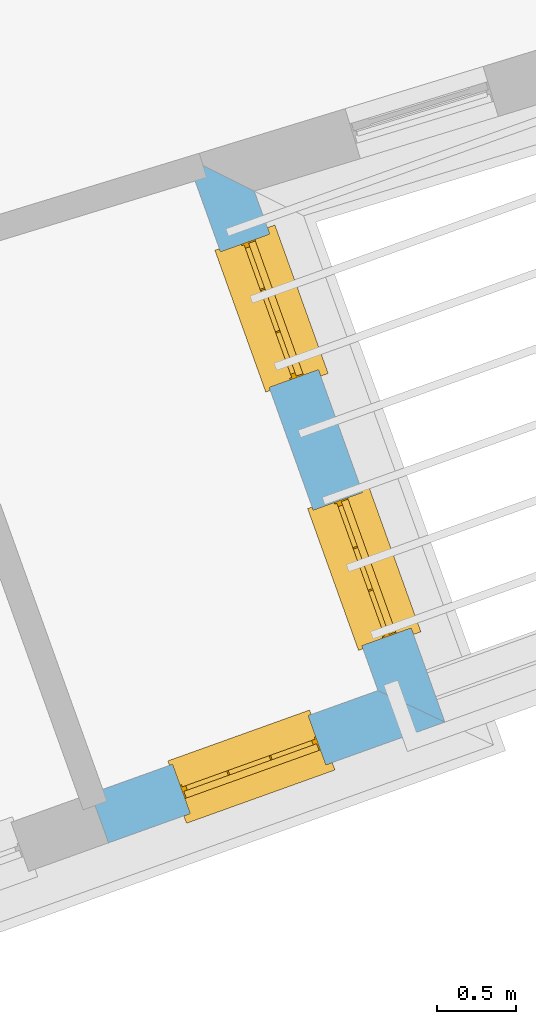
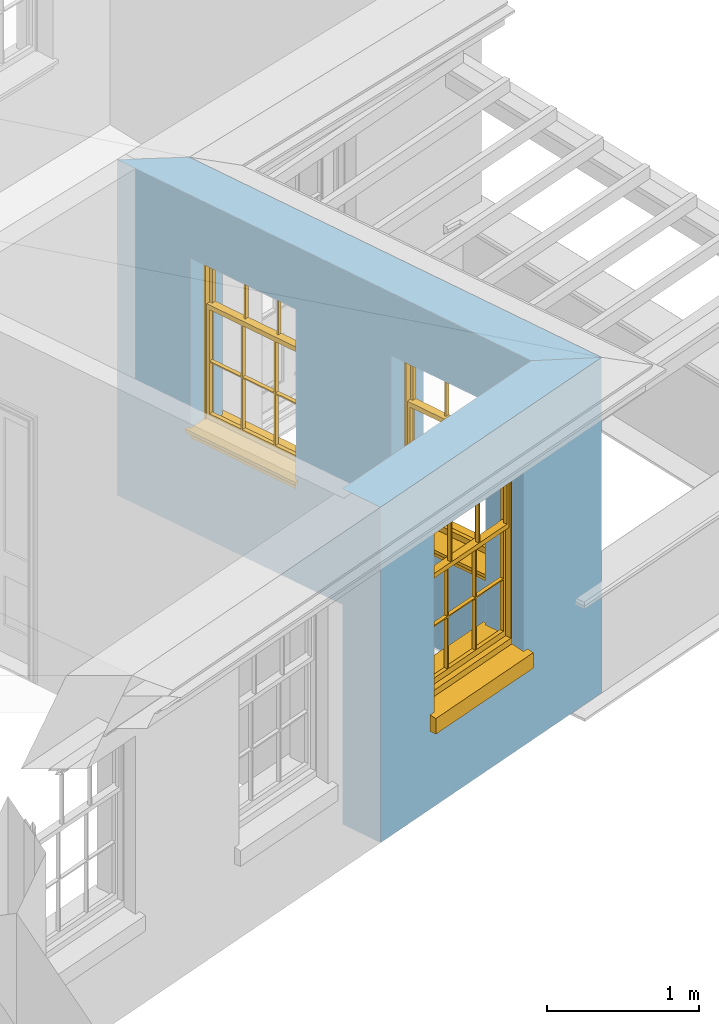
# One storey, part 6 of 10: 3 windows, 3 openings, plus 2 elements that do not belong to this part.
"""IFC2X3 building model written with IfcOpenShell, lengths in metres."""

from ifc_helpers import new_model, si_unit, frame, origin, place, context, subcontext, project, spatial, polyline, outline, extrude, faceted_brep, material, layer, layer_set, layer_usage, element, fill, save


model = new_model("IFC2X3")

# Units and contexts
model_context = context("Model", 3, world=origin())
body_context = subcontext(model_context, "Body", "Model", "MODEL_VIEW")
ifc_project = project(units=[si_unit("PLANEANGLEUNIT", "RADIAN"), si_unit("MASSUNIT", "GRAM", prefix="KILO"), si_unit("FORCEUNIT", "NEWTON", prefix="KILO"), si_unit("LENGTHUNIT", "METRE")], contexts=[model_context])

# Site, building, storey
site_placement = place(None, origin())
site = spatial("IfcSite", under=ifc_project, at=site_placement, CompositionType="ELEMENT")
building_placement = place(None, origin())
building = spatial("IfcBuilding", under=site, at=building_placement, Name="Building plot-9", CompositionType="ELEMENT")
storey_placement = place(None, frame((0.0, 0.0, 4.3)))
storey = spatial("IfcBuildingStorey", under=building, at=storey_placement, Name="Floor 1", CompositionType="ELEMENT", Elevation=4.3)

# Wall, opening, window
ifc_material = material(Name="Masonry")
ifc_layer = layer(ifc_material, 0.33, ventilated=False)
ifc_layer_set = layer_set([ifc_layer], Name="My Wall")
ifc_layer_usage = layer_usage(ifc_layer_set, "AXIS2", "NEGATIVE", 0.08)
wall_1_placement = place(storey_placement, origin())
wall_1 = element("IfcWallStandardCase", 1, at=wall_1_placement, inside=storey, material=ifc_layer_usage, Name="exterior", context=body_context, shape_type="SweptSolid", body=[
    extrude(outline(polyline([(37.5711045809664, 15.9166544077497), (37.6825977583454, 15.6060593797825), (39.8049850615781, 16.3679250980293), (39.382896856232, 16.5670269486175), (37.5711045809664, 15.9166544077497)])), origin(), (0.0, 0.0, 1.0), 2.7),
])
opening_1_placement = place(storey_placement, frame((0.0, 0.0, 0.75)))
opening_1 = element("IfcOpeningElement", 2, at=opening_1_placement, cuts=wall_1, Name="Opening", ObjectType="Opening", context=body_context, shape_type="SweptSolid", body=[
    extrude(outline(polyline([(38.197897118383, 15.7910345332096), (39.0543864379289, 16.0984854162848), (38.94289326055, 16.409080444252), (38.0864039410041, 16.1016295611768), (38.197897118383, 15.7910345332096)])), origin(), (0.0, 0.0, 1.0), 1.445),
])
window_1_placement = place(storey_placement, frame((38.1134325900656, 16.0263337968211, 0.75), z_axis=(0.0, 0.0, 1.0), x_axis=(0.856489319545943, 0.307450883075226, 0.0)))
window_1 = element("IfcWindow", 3, at=window_1_placement, inside=storey, Name="toilet outside window", OverallHeight=1.445, OverallWidth=0.91, context=body_context, shape_type="Brep", held_by="IfcProductRepresentation", body=[
    faceted_brep([(0.876875, -0.105, 0.999097), (0.876875, -0.105, 1.411875), (0.9, -0.105, 1.435), (0.033125, -0.105, 1.411875), (0.033125, -0.105, 0.999097), (0.01, -0.105, 1.435), (0.033125, -0.135, 1.411875), (0.01, -0.135, 1.435), (0.033125, -0.135, 0.999097), (0.876875, -0.135, 1.411875), (0.876875, -0.135, 0.999097), (0.9, -0.135, 1.435), (0.033125, -0.105, 0.960972), (0.01, -0.105, 0.960972), (0.033125, -0.105, 0.548195), (0.876875, -0.105, 0.960972), (0.876875, -0.105, 0.548195), (0.9, -0.105, 0.960972), (0.876875, -0.105, 0.538195), (0.876875, -0.105, 0.125417), (0.9, -0.105, 0.077167), (0.033125, -0.105, 0.125417), (0.033125, -0.105, 0.538195), (0.01, -0.105, 0.077167), (0.9, -0.135, 0.960972), (0.01, -0.135, 0.960972), (-0.0425, -0.25, 0.01), (-0.0425, -0.3, 0.001667), (0.0, -0.25, 0.01), (0.9525, -0.25, 0.01), (0.91, -0.25, 0.01), (0.9525, -0.3, 0.001667), (-0.02, 0.08, 0.077167), (0.0, 0.08, 0.077167), (-0.02, 0.11, 0.077167), (0.0, -0.06, 0.077167), (0.01, -0.06, 0.077167), (0.91, -0.06, 0.077167), (0.91, 0.08, 0.077167), (0.9, -0.06, 0.077167), (0.93, 0.08, 0.077167), (0.93, 0.11, 0.077167), (0.01, -0.105, 0.999097), (0.01, -0.075, 0.999097), (0.9, -0.105, 0.999097), (0.9, -0.075, 0.999097), (0.876875, -0.075, 0.125417), (0.876875, -0.075, 0.538195), (0.9, -0.075, 0.077167), (0.876875, -0.075, 0.548195), (0.876875, -0.075, 0.960972), (0.033125, -0.075, 0.125417), (0.01, -0.075, 0.077167), (0.033125, -0.075, 0.538195), (0.033125, -0.075, 0.960972), (0.033125, -0.075, 0.548195), (-0.02, 0.08, 0.052167), (-0.02, 0.11, 0.052167), (0.93, 0.11, 0.052167), (0.93, 0.08, 0.052167), (0.91, 0.08, 0.052167), (0.0, 0.08, 0.052167), (0.91, -0.15, 0.026667), (0.0, -0.15, 0.026667), (-0.0425, -0.3, -0.123333), (0.9525, -0.3, -0.123333), (-0.0425, -0.25, -0.123333), (0.9525, -0.25, -0.123333), (0.01, -0.06, 1.435), (0.9, -0.06, 1.435), (0.0, -0.06, 1.445), (0.91, -0.06, 1.445), (0.01, -0.15, 0.077167), (0.9, -0.15, 0.077167), (0.592292, -0.105, 0.125417), (0.592292, -0.075, 0.125417), (0.317708, -0.075, 0.125417), (0.317708, -0.105, 0.125417), (0.592292, -0.105, 0.548195), (0.317708, -0.105, 0.548195), (0.317708, -0.105, 0.538195), (0.592292, -0.105, 0.538195), (0.592292, -0.075, 0.548195), (0.317708, -0.075, 0.548195), (0.602292, -0.075, 0.548195), (0.602292, -0.105, 0.548195), (0.317708, -0.075, 0.538195), (0.307708, -0.075, 0.125417), (0.307708, -0.075, 0.538195), (0.602292, -0.075, 0.538195), (0.602292, -0.075, 0.125417), (0.592292, -0.075, 0.538195), (0.307708, -0.075, 0.548195), (0.317708, -0.075, 0.960972), (0.307708, -0.075, 0.960972), (0.602292, -0.075, 0.960972), (0.592292, -0.075, 0.960972), (0.307708, -0.105, 0.538195), (0.307708, -0.105, 0.125417), (0.307708, -0.105, 0.548195), (0.307708, -0.105, 0.960972), (0.592292, -0.105, 0.960972), (0.317708, -0.105, 0.960972), (0.602292, -0.105, 0.960972), (0.602292, -0.105, 0.538195), (0.602292, -0.105, 0.125417), (0.317708, -0.135, 1.411875), (0.307708, -0.135, 1.411875), (0.307708, -0.135, 0.999097), (0.317708, -0.135, 0.999097), (0.602292, -0.135, 1.411875), (0.592292, -0.135, 1.411875), (0.592292, -0.135, 0.999097), (0.602292, -0.135, 0.999097), (0.317708, -0.105, 0.999097), (0.307708, -0.105, 0.999097), (0.307708, -0.105, 1.411875), (0.317708, -0.105, 1.411875), (0.602292, -0.105, 0.999097), (0.592292, -0.105, 0.999097), (0.592292, -0.105, 1.411875), (0.602292, -0.105, 1.411875), (0.91, -0.15, 1.445), (0.9, -0.15, 1.435), (0.01, -0.15, 1.435), (0.0, -0.15, 1.445), (0.91, -0.25, 0.0), (0.0, -0.25, 0.0), (0.91, 0.08, 0.0), (0.0, 0.08, 0.0)], [[[0, 1, 2]], [[3, 4, 5]], [[6, 7, 8]], [[9, 10, 11]], [[12, 13, 14]], [[15, 16, 17]], [[18, 19, 20]], [[21, 22, 23]], [[24, 15, 17]], [[13, 12, 25]], [[26, 27, 28]], [[29, 30, 31]], [[32, 33, 34]], [[35, 36, 33]], [[37, 38, 39]], [[40, 41, 38]], [[42, 4, 43]], [[44, 45, 0]], [[46, 47, 48]], [[49, 50, 45]], [[51, 52, 53]], [[54, 55, 43]], [[38, 33, 36, 39]], [[41, 34, 33, 38]], [[56, 32, 34, 57]], [[57, 34, 41, 58]], [[58, 41, 40, 59]], [[57, 58, 60, 61]], [[52, 48, 39, 36]], [[62, 63, 28, 30]], [[27, 31, 30, 28]], [[27, 64, 65, 31]], [[66, 67, 65, 64]], [[2, 5, 68, 69]], [[68, 70, 71, 69]], [[20, 23, 72, 73]], [[73, 72, 63, 62]], [[74, 75, 76, 77]], [[78, 79, 80, 81]], [[78, 82, 83, 79]], [[16, 49, 84, 85]], [[86, 76, 87, 88]], [[89, 90, 75, 91]], [[92, 88, 53, 55]], [[82, 91, 86, 83]], [[93, 83, 92, 94]], [[95, 84, 82, 96]], [[89, 84, 49, 47]], [[97, 88, 87, 98]], [[22, 53, 88, 97]], [[81, 91, 75, 74]], [[80, 86, 91, 81]], [[77, 76, 86, 80]], [[99, 92, 55, 14]], [[100, 94, 92, 99]], [[101, 96, 82, 78]], [[79, 83, 93, 102]], [[85, 84, 95, 103]], [[104, 89, 47, 18]], [[105, 90, 89, 104]], [[104, 18, 16, 85]], [[80, 97, 98, 77]], [[104, 81, 74, 105]], [[103, 101, 78, 85]], [[99, 14, 22, 97]], [[102, 100, 99, 79]], [[106, 107, 108, 109]], [[110, 111, 112, 113]], [[114, 115, 116, 117]], [[118, 119, 120, 121]], [[107, 116, 115, 108]], [[111, 120, 119, 112]], [[109, 114, 117, 106]], [[113, 118, 121, 110]], [[85, 78, 81, 104]], [[84, 89, 91, 82]], [[83, 86, 88, 92]], [[79, 99, 97, 80]], [[109, 112, 119, 114]], [[102, 93, 96, 101]], [[106, 117, 120, 111]], [[98, 87, 51, 21]], [[6, 3, 116, 107]], [[110, 121, 1, 9]], [[19, 46, 90, 105]], [[26, 66, 64, 27]], [[29, 31, 65, 67]], [[25, 24, 112, 109]], [[11, 7, 106, 111]], [[75, 48, 52, 76]], [[43, 45, 96, 93]], [[45, 43, 114, 119]], [[5, 2, 120, 117]], [[24, 25, 102, 101]], [[42, 5, 4]], [[2, 44, 0]], [[49, 45, 48, 47]], [[52, 43, 55, 53]], [[14, 13, 23, 22]], [[20, 17, 16, 18]], [[24, 11, 10]], [[25, 8, 7]], [[8, 4, 3, 6]], [[9, 1, 0, 10]], [[15, 50, 49, 16]], [[18, 47, 46, 19]], [[21, 51, 53, 22]], [[14, 55, 54, 12]], [[44, 2, 69, 45]], [[68, 5, 42, 43]], [[36, 35, 70, 68]], [[39, 69, 71, 37]], [[62, 122, 123, 73]], [[63, 72, 124, 125]], [[8, 108, 115, 4]], [[113, 10, 0, 118]], [[94, 100, 12, 54]], [[17, 20, 73, 24]], [[72, 23, 13, 25]], [[52, 36, 68, 43]], [[69, 39, 48, 45]], [[11, 24, 73, 123]], [[7, 124, 72, 25]], [[23, 77, 98]], [[98, 21, 23]], [[105, 74, 20]], [[20, 19, 105]], [[20, 74, 77, 23]], [[113, 112, 24]], [[24, 10, 113]], [[25, 109, 108]], [[108, 8, 25]], [[110, 9, 11]], [[11, 111, 110]], [[7, 6, 107]], [[107, 106, 7]], [[5, 117, 116]], [[116, 3, 5]], [[121, 120, 2]], [[2, 1, 121]], [[11, 123, 124, 7]], [[122, 125, 124, 123]], [[43, 93, 94]], [[94, 54, 43]], [[96, 45, 95]], [[50, 95, 45]], [[15, 103, 95, 50]], [[48, 75, 90]], [[90, 46, 48]], [[87, 76, 52]], [[52, 51, 87]], [[103, 15, 24]], [[24, 101, 103]], [[100, 102, 25]], [[25, 12, 100]], [[115, 114, 43]], [[43, 4, 115]], [[118, 0, 45]], [[45, 119, 118]], [[71, 70, 125, 122]], [[70, 35, 63, 125]], [[122, 62, 37, 71]], [[126, 67, 66, 127]], [[60, 58, 59]], [[38, 60, 59, 40]], [[61, 56, 57]], [[32, 56, 61, 33]], [[61, 60, 128, 129]], [[62, 60, 38, 37]], [[126, 128, 60, 62]], [[33, 61, 63, 35]], [[61, 129, 127, 63]], [[128, 126, 127, 129]], [[28, 127, 66, 26]], [[63, 127, 28]], [[29, 67, 126, 30]], [[30, 126, 62]]]),
])
fill(opening_1, window_1)

# Wall, openings, windows
wall_2_placement = place(storey_placement, origin())
wall_2 = element("IfcWallStandardCase", 4, at=wall_2_placement, inside=storey, material=ifc_layer_usage, Name="exterior", context=body_context, shape_type="SweptSolid", body=[
    extrude(outline(polyline([(39.382896856232, 16.5670269486175), (39.8049850615781, 16.3679250980293), (38.6024618598675, 19.7178854834714), (38.174894424001, 19.9322512434462), (39.382896856232, 16.5670269486175)])), origin(), (0.0, 0.0, 1.0), 2.7),
])
opening_2_placement = place(storey_placement, frame((0.0, 0.0, 0.75)))
opening_2 = element("IfcOpeningElement", 5, at=opening_2_placement, cuts=wall_2, Name="Opening", ObjectType="Opening", context=body_context, shape_type="SweptSolid", body=[
    extrude(outline(polyline([(39.5921344502183, 16.9608792423303), (39.2846835671431, 17.8173685618762), (38.9740885391759, 17.7058753844973), (39.2815394222511, 16.8493860649514), (39.5921344502183, 16.9608792423303)])), origin(), (0.0, 0.0, 1.0), 1.445),
])
opening_3_placement = place(storey_placement, frame((0.0, 0.0, 0.75)))
opening_3 = element("IfcOpeningElement", 6, at=opening_3_placement, cuts=wall_2, Name="Opening", ObjectType="Opening", context=body_context, shape_type="SweptSolid", body=[
    extrude(outline(polyline([(39.0071192447112, 18.5906006153087), (38.6996683616359, 19.4470899348546), (38.3890733336687, 19.3355967574757), (38.696524216744, 18.4791074379298), (39.0071192447112, 18.5906006153087)])), origin(), (0.0, 0.0, 1.0), 1.445),
])
window_2_placement = place(storey_placement, frame((39.3568351866068, 16.8764147140129, 0.75), z_axis=(0.0, 0.0, 1.0), x_axis=(-0.307450883075248, 0.856489319545933, 0.0)))
window_2 = element("IfcWindow", 7, at=window_2_placement, inside=storey, Name="toilet outside window", OverallHeight=1.445, OverallWidth=0.91, context=body_context, shape_type="Brep", held_by="IfcProductRepresentation", body=[
    faceted_brep([(0.876875, -0.105, 0.999097), (0.876875, -0.105, 1.411875), (0.9, -0.105, 1.435), (0.033125, -0.105, 1.411875), (0.033125, -0.105, 0.999097), (0.01, -0.105, 1.435), (0.033125, -0.135, 1.411875), (0.01, -0.135, 1.435), (0.033125, -0.135, 0.999097), (0.876875, -0.135, 1.411875), (0.876875, -0.135, 0.999097), (0.9, -0.135, 1.435), (0.033125, -0.105, 0.960972), (0.01, -0.105, 0.960972), (0.033125, -0.105, 0.548195), (0.876875, -0.105, 0.960972), (0.876875, -0.105, 0.548195), (0.9, -0.105, 0.960972), (0.876875, -0.105, 0.538195), (0.876875, -0.105, 0.125417), (0.9, -0.105, 0.077167), (0.033125, -0.105, 0.125417), (0.033125, -0.105, 0.538195), (0.01, -0.105, 0.077167), (0.9, -0.135, 0.960972), (0.01, -0.135, 0.960972), (-0.0425, -0.25, 0.01), (-0.0425, -0.3, 0.001667), (0.0, -0.25, 0.01), (0.9525, -0.25, 0.01), (0.91, -0.25, 0.01), (0.9525, -0.3, 0.001667), (-0.02, 0.08, 0.077167), (0.0, 0.08, 0.077167), (-0.02, 0.11, 0.077167), (0.0, -0.06, 0.077167), (0.01, -0.06, 0.077167), (0.91, -0.06, 0.077167), (0.91, 0.08, 0.077167), (0.9, -0.06, 0.077167), (0.93, 0.08, 0.077167), (0.93, 0.11, 0.077167), (0.01, -0.105, 0.999097), (0.01, -0.075, 0.999097), (0.9, -0.105, 0.999097), (0.9, -0.075, 0.999097), (0.876875, -0.075, 0.125417), (0.876875, -0.075, 0.538195), (0.9, -0.075, 0.077167), (0.876875, -0.075, 0.548195), (0.876875, -0.075, 0.960972), (0.033125, -0.075, 0.125417), (0.01, -0.075, 0.077167), (0.033125, -0.075, 0.538195), (0.033125, -0.075, 0.960972), (0.033125, -0.075, 0.548195), (-0.02, 0.08, 0.052167), (-0.02, 0.11, 0.052167), (0.93, 0.11, 0.052167), (0.93, 0.08, 0.052167), (0.91, 0.08, 0.052167), (0.0, 0.08, 0.052167), (0.91, -0.15, 0.026667), (0.0, -0.15, 0.026667), (-0.0425, -0.3, -0.123333), (0.9525, -0.3, -0.123333), (-0.0425, -0.25, -0.123333), (0.9525, -0.25, -0.123333), (0.01, -0.06, 1.435), (0.9, -0.06, 1.435), (0.0, -0.06, 1.445), (0.91, -0.06, 1.445), (0.01, -0.15, 0.077167), (0.9, -0.15, 0.077167), (0.592292, -0.105, 0.125417), (0.592292, -0.075, 0.125417), (0.317708, -0.075, 0.125417), (0.317708, -0.105, 0.125417), (0.592292, -0.105, 0.548195), (0.317708, -0.105, 0.548195), (0.317708, -0.105, 0.538195), (0.592292, -0.105, 0.538195), (0.592292, -0.075, 0.548195), (0.317708, -0.075, 0.548195), (0.602292, -0.075, 0.548195), (0.602292, -0.105, 0.548195), (0.317708, -0.075, 0.538195), (0.307708, -0.075, 0.125417), (0.307708, -0.075, 0.538195), (0.602292, -0.075, 0.538195), (0.602292, -0.075, 0.125417), (0.592292, -0.075, 0.538195), (0.307708, -0.075, 0.548195), (0.317708, -0.075, 0.960972), (0.307708, -0.075, 0.960972), (0.602292, -0.075, 0.960972), (0.592292, -0.075, 0.960972), (0.307708, -0.105, 0.538195), (0.307708, -0.105, 0.125417), (0.307708, -0.105, 0.548195), (0.307708, -0.105, 0.960972), (0.592292, -0.105, 0.960972), (0.317708, -0.105, 0.960972), (0.602292, -0.105, 0.960972), (0.602292, -0.105, 0.538195), (0.602292, -0.105, 0.125417), (0.317708, -0.135, 1.411875), (0.307708, -0.135, 1.411875), (0.307708, -0.135, 0.999097), (0.317708, -0.135, 0.999097), (0.602292, -0.135, 1.411875), (0.592292, -0.135, 1.411875), (0.592292, -0.135, 0.999097), (0.602292, -0.135, 0.999097), (0.317708, -0.105, 0.999097), (0.307708, -0.105, 0.999097), (0.307708, -0.105, 1.411875), (0.317708, -0.105, 1.411875), (0.602292, -0.105, 0.999097), (0.592292, -0.105, 0.999097), (0.592292, -0.105, 1.411875), (0.602292, -0.105, 1.411875), (0.91, -0.15, 1.445), (0.9, -0.15, 1.435), (0.01, -0.15, 1.435), (0.0, -0.15, 1.445), (0.91, -0.25, 0.0), (0.0, -0.25, 0.0), (0.91, 0.08, 0.0), (0.0, 0.08, 0.0)], [[[0, 1, 2]], [[3, 4, 5]], [[6, 7, 8]], [[9, 10, 11]], [[12, 13, 14]], [[15, 16, 17]], [[18, 19, 20]], [[21, 22, 23]], [[24, 15, 17]], [[13, 12, 25]], [[26, 27, 28]], [[29, 30, 31]], [[32, 33, 34]], [[35, 36, 33]], [[37, 38, 39]], [[40, 41, 38]], [[42, 4, 43]], [[44, 45, 0]], [[46, 47, 48]], [[49, 50, 45]], [[51, 52, 53]], [[54, 55, 43]], [[38, 33, 36, 39]], [[41, 34, 33, 38]], [[56, 32, 34, 57]], [[57, 34, 41, 58]], [[58, 41, 40, 59]], [[57, 58, 60, 61]], [[52, 48, 39, 36]], [[62, 63, 28, 30]], [[27, 31, 30, 28]], [[27, 64, 65, 31]], [[66, 67, 65, 64]], [[2, 5, 68, 69]], [[68, 70, 71, 69]], [[20, 23, 72, 73]], [[73, 72, 63, 62]], [[74, 75, 76, 77]], [[78, 79, 80, 81]], [[78, 82, 83, 79]], [[16, 49, 84, 85]], [[86, 76, 87, 88]], [[89, 90, 75, 91]], [[92, 88, 53, 55]], [[82, 91, 86, 83]], [[93, 83, 92, 94]], [[95, 84, 82, 96]], [[89, 84, 49, 47]], [[97, 88, 87, 98]], [[22, 53, 88, 97]], [[81, 91, 75, 74]], [[80, 86, 91, 81]], [[77, 76, 86, 80]], [[99, 92, 55, 14]], [[100, 94, 92, 99]], [[101, 96, 82, 78]], [[79, 83, 93, 102]], [[85, 84, 95, 103]], [[104, 89, 47, 18]], [[105, 90, 89, 104]], [[104, 18, 16, 85]], [[80, 97, 98, 77]], [[104, 81, 74, 105]], [[103, 101, 78, 85]], [[99, 14, 22, 97]], [[102, 100, 99, 79]], [[106, 107, 108, 109]], [[110, 111, 112, 113]], [[114, 115, 116, 117]], [[118, 119, 120, 121]], [[107, 116, 115, 108]], [[111, 120, 119, 112]], [[109, 114, 117, 106]], [[113, 118, 121, 110]], [[85, 78, 81, 104]], [[84, 89, 91, 82]], [[83, 86, 88, 92]], [[79, 99, 97, 80]], [[109, 112, 119, 114]], [[102, 93, 96, 101]], [[106, 117, 120, 111]], [[98, 87, 51, 21]], [[6, 3, 116, 107]], [[110, 121, 1, 9]], [[19, 46, 90, 105]], [[26, 66, 64, 27]], [[29, 31, 65, 67]], [[25, 24, 112, 109]], [[11, 7, 106, 111]], [[75, 48, 52, 76]], [[43, 45, 96, 93]], [[45, 43, 114, 119]], [[5, 2, 120, 117]], [[24, 25, 102, 101]], [[42, 5, 4]], [[2, 44, 0]], [[49, 45, 48, 47]], [[52, 43, 55, 53]], [[14, 13, 23, 22]], [[20, 17, 16, 18]], [[24, 11, 10]], [[25, 8, 7]], [[8, 4, 3, 6]], [[9, 1, 0, 10]], [[15, 50, 49, 16]], [[18, 47, 46, 19]], [[21, 51, 53, 22]], [[14, 55, 54, 12]], [[44, 2, 69, 45]], [[68, 5, 42, 43]], [[36, 35, 70, 68]], [[39, 69, 71, 37]], [[62, 122, 123, 73]], [[63, 72, 124, 125]], [[8, 108, 115, 4]], [[113, 10, 0, 118]], [[94, 100, 12, 54]], [[17, 20, 73, 24]], [[72, 23, 13, 25]], [[52, 36, 68, 43]], [[69, 39, 48, 45]], [[11, 24, 73, 123]], [[7, 124, 72, 25]], [[23, 77, 98]], [[98, 21, 23]], [[105, 74, 20]], [[20, 19, 105]], [[20, 74, 77, 23]], [[113, 112, 24]], [[24, 10, 113]], [[25, 109, 108]], [[108, 8, 25]], [[110, 9, 11]], [[11, 111, 110]], [[7, 6, 107]], [[107, 106, 7]], [[5, 117, 116]], [[116, 3, 5]], [[121, 120, 2]], [[2, 1, 121]], [[11, 123, 124, 7]], [[122, 125, 124, 123]], [[43, 93, 94]], [[94, 54, 43]], [[96, 45, 95]], [[50, 95, 45]], [[15, 103, 95, 50]], [[48, 75, 90]], [[90, 46, 48]], [[87, 76, 52]], [[52, 51, 87]], [[103, 15, 24]], [[24, 101, 103]], [[100, 102, 25]], [[25, 12, 100]], [[115, 114, 43]], [[43, 4, 115]], [[118, 0, 45]], [[45, 119, 118]], [[71, 70, 125, 122]], [[70, 35, 63, 125]], [[122, 62, 37, 71]], [[126, 67, 66, 127]], [[60, 58, 59]], [[38, 60, 59, 40]], [[61, 56, 57]], [[32, 56, 61, 33]], [[61, 60, 128, 129]], [[62, 60, 38, 37]], [[126, 128, 60, 62]], [[33, 61, 63, 35]], [[61, 129, 127, 63]], [[128, 126, 127, 129]], [[28, 127, 66, 26]], [[63, 127, 28]], [[29, 67, 126, 30]], [[30, 126, 62]]]),
])
fill(opening_2, window_2)
window_3_placement = place(storey_placement, frame((38.7718199810997, 18.5061360869913, 0.75), z_axis=(0.0, 0.0, 1.0), x_axis=(-0.307450883075241, 0.856489319545933, 0.0)))
window_3 = element("IfcWindow", 8, at=window_3_placement, inside=storey, Name="toilet outside window", OverallHeight=1.445, OverallWidth=0.91, context=body_context, shape_type="Brep", held_by="IfcProductRepresentation", body=[
    faceted_brep([(0.876875, -0.105, 0.999097), (0.876875, -0.105, 1.411875), (0.9, -0.105, 1.435), (0.033125, -0.105, 1.411875), (0.033125, -0.105, 0.999097), (0.01, -0.105, 1.435), (0.033125, -0.135, 1.411875), (0.01, -0.135, 1.435), (0.033125, -0.135, 0.999097), (0.876875, -0.135, 1.411875), (0.876875, -0.135, 0.999097), (0.9, -0.135, 1.435), (0.033125, -0.105, 0.960972), (0.01, -0.105, 0.960972), (0.033125, -0.105, 0.548195), (0.876875, -0.105, 0.960972), (0.876875, -0.105, 0.548195), (0.9, -0.105, 0.960972), (0.876875, -0.105, 0.538195), (0.876875, -0.105, 0.125417), (0.9, -0.105, 0.077167), (0.033125, -0.105, 0.125417), (0.033125, -0.105, 0.538195), (0.01, -0.105, 0.077167), (0.9, -0.135, 0.960972), (0.01, -0.135, 0.960972), (-0.0425, -0.25, 0.01), (-0.0425, -0.3, 0.001667), (0.0, -0.25, 0.01), (0.9525, -0.25, 0.01), (0.91, -0.25, 0.01), (0.9525, -0.3, 0.001667), (-0.02, 0.08, 0.077167), (0.0, 0.08, 0.077167), (-0.02, 0.11, 0.077167), (0.0, -0.06, 0.077167), (0.01, -0.06, 0.077167), (0.91, -0.06, 0.077167), (0.91, 0.08, 0.077167), (0.9, -0.06, 0.077167), (0.93, 0.08, 0.077167), (0.93, 0.11, 0.077167), (0.01, -0.105, 0.999097), (0.01, -0.075, 0.999097), (0.9, -0.105, 0.999097), (0.9, -0.075, 0.999097), (0.876875, -0.075, 0.125417), (0.876875, -0.075, 0.538195), (0.9, -0.075, 0.077167), (0.876875, -0.075, 0.548195), (0.876875, -0.075, 0.960972), (0.033125, -0.075, 0.125417), (0.01, -0.075, 0.077167), (0.033125, -0.075, 0.538195), (0.033125, -0.075, 0.960972), (0.033125, -0.075, 0.548195), (-0.02, 0.08, 0.052167), (-0.02, 0.11, 0.052167), (0.93, 0.11, 0.052167), (0.93, 0.08, 0.052167), (0.91, 0.08, 0.052167), (0.0, 0.08, 0.052167), (0.91, -0.15, 0.026667), (0.0, -0.15, 0.026667), (-0.0425, -0.3, -0.123333), (0.9525, -0.3, -0.123333), (-0.0425, -0.25, -0.123333), (0.9525, -0.25, -0.123333), (0.01, -0.06, 1.435), (0.9, -0.06, 1.435), (0.0, -0.06, 1.445), (0.91, -0.06, 1.445), (0.01, -0.15, 0.077167), (0.9, -0.15, 0.077167), (0.592292, -0.105, 0.125417), (0.592292, -0.075, 0.125417), (0.317708, -0.075, 0.125417), (0.317708, -0.105, 0.125417), (0.592292, -0.105, 0.548195), (0.317708, -0.105, 0.548195), (0.317708, -0.105, 0.538195), (0.592292, -0.105, 0.538195), (0.592292, -0.075, 0.548195), (0.317708, -0.075, 0.548195), (0.602292, -0.075, 0.548195), (0.602292, -0.105, 0.548195), (0.317708, -0.075, 0.538195), (0.307708, -0.075, 0.125417), (0.307708, -0.075, 0.538195), (0.602292, -0.075, 0.538195), (0.602292, -0.075, 0.125417), (0.592292, -0.075, 0.538195), (0.307708, -0.075, 0.548195), (0.317708, -0.075, 0.960972), (0.307708, -0.075, 0.960972), (0.602292, -0.075, 0.960972), (0.592292, -0.075, 0.960972), (0.307708, -0.105, 0.538195), (0.307708, -0.105, 0.125417), (0.307708, -0.105, 0.548195), (0.307708, -0.105, 0.960972), (0.592292, -0.105, 0.960972), (0.317708, -0.105, 0.960972), (0.602292, -0.105, 0.960972), (0.602292, -0.105, 0.538195), (0.602292, -0.105, 0.125417), (0.317708, -0.135, 1.411875), (0.307708, -0.135, 1.411875), (0.307708, -0.135, 0.999097), (0.317708, -0.135, 0.999097), (0.602292, -0.135, 1.411875), (0.592292, -0.135, 1.411875), (0.592292, -0.135, 0.999097), (0.602292, -0.135, 0.999097), (0.317708, -0.105, 0.999097), (0.307708, -0.105, 0.999097), (0.307708, -0.105, 1.411875), (0.317708, -0.105, 1.411875), (0.602292, -0.105, 0.999097), (0.592292, -0.105, 0.999097), (0.592292, -0.105, 1.411875), (0.602292, -0.105, 1.411875), (0.91, -0.15, 1.445), (0.9, -0.15, 1.435), (0.01, -0.15, 1.435), (0.0, -0.15, 1.445), (0.91, -0.25, 0.0), (0.0, -0.25, 0.0), (0.91, 0.08, 0.0), (0.0, 0.08, 0.0)], [[[0, 1, 2]], [[3, 4, 5]], [[6, 7, 8]], [[9, 10, 11]], [[12, 13, 14]], [[15, 16, 17]], [[18, 19, 20]], [[21, 22, 23]], [[24, 15, 17]], [[13, 12, 25]], [[26, 27, 28]], [[29, 30, 31]], [[32, 33, 34]], [[35, 36, 33]], [[37, 38, 39]], [[40, 41, 38]], [[42, 4, 43]], [[44, 45, 0]], [[46, 47, 48]], [[49, 50, 45]], [[51, 52, 53]], [[54, 55, 43]], [[38, 33, 36, 39]], [[41, 34, 33, 38]], [[56, 32, 34, 57]], [[57, 34, 41, 58]], [[58, 41, 40, 59]], [[57, 58, 60, 61]], [[52, 48, 39, 36]], [[62, 63, 28, 30]], [[27, 31, 30, 28]], [[27, 64, 65, 31]], [[66, 67, 65, 64]], [[2, 5, 68, 69]], [[68, 70, 71, 69]], [[20, 23, 72, 73]], [[73, 72, 63, 62]], [[74, 75, 76, 77]], [[78, 79, 80, 81]], [[78, 82, 83, 79]], [[16, 49, 84, 85]], [[86, 76, 87, 88]], [[89, 90, 75, 91]], [[92, 88, 53, 55]], [[82, 91, 86, 83]], [[93, 83, 92, 94]], [[95, 84, 82, 96]], [[89, 84, 49, 47]], [[97, 88, 87, 98]], [[22, 53, 88, 97]], [[81, 91, 75, 74]], [[80, 86, 91, 81]], [[77, 76, 86, 80]], [[99, 92, 55, 14]], [[100, 94, 92, 99]], [[101, 96, 82, 78]], [[79, 83, 93, 102]], [[85, 84, 95, 103]], [[104, 89, 47, 18]], [[105, 90, 89, 104]], [[104, 18, 16, 85]], [[80, 97, 98, 77]], [[104, 81, 74, 105]], [[103, 101, 78, 85]], [[99, 14, 22, 97]], [[102, 100, 99, 79]], [[106, 107, 108, 109]], [[110, 111, 112, 113]], [[114, 115, 116, 117]], [[118, 119, 120, 121]], [[107, 116, 115, 108]], [[111, 120, 119, 112]], [[109, 114, 117, 106]], [[113, 118, 121, 110]], [[85, 78, 81, 104]], [[84, 89, 91, 82]], [[83, 86, 88, 92]], [[79, 99, 97, 80]], [[109, 112, 119, 114]], [[102, 93, 96, 101]], [[106, 117, 120, 111]], [[98, 87, 51, 21]], [[6, 3, 116, 107]], [[110, 121, 1, 9]], [[19, 46, 90, 105]], [[26, 66, 64, 27]], [[29, 31, 65, 67]], [[25, 24, 112, 109]], [[11, 7, 106, 111]], [[75, 48, 52, 76]], [[43, 45, 96, 93]], [[45, 43, 114, 119]], [[5, 2, 120, 117]], [[24, 25, 102, 101]], [[42, 5, 4]], [[2, 44, 0]], [[49, 45, 48, 47]], [[52, 43, 55, 53]], [[14, 13, 23, 22]], [[20, 17, 16, 18]], [[24, 11, 10]], [[25, 8, 7]], [[8, 4, 3, 6]], [[9, 1, 0, 10]], [[15, 50, 49, 16]], [[18, 47, 46, 19]], [[21, 51, 53, 22]], [[14, 55, 54, 12]], [[44, 2, 69, 45]], [[68, 5, 42, 43]], [[36, 35, 70, 68]], [[39, 69, 71, 37]], [[62, 122, 123, 73]], [[63, 72, 124, 125]], [[8, 108, 115, 4]], [[113, 10, 0, 118]], [[94, 100, 12, 54]], [[17, 20, 73, 24]], [[72, 23, 13, 25]], [[52, 36, 68, 43]], [[69, 39, 48, 45]], [[11, 24, 73, 123]], [[7, 124, 72, 25]], [[23, 77, 98]], [[98, 21, 23]], [[105, 74, 20]], [[20, 19, 105]], [[20, 74, 77, 23]], [[113, 112, 24]], [[24, 10, 113]], [[25, 109, 108]], [[108, 8, 25]], [[110, 9, 11]], [[11, 111, 110]], [[7, 6, 107]], [[107, 106, 7]], [[5, 117, 116]], [[116, 3, 5]], [[121, 120, 2]], [[2, 1, 121]], [[11, 123, 124, 7]], [[122, 125, 124, 123]], [[43, 93, 94]], [[94, 54, 43]], [[96, 45, 95]], [[50, 95, 45]], [[15, 103, 95, 50]], [[48, 75, 90]], [[90, 46, 48]], [[87, 76, 52]], [[52, 51, 87]], [[103, 15, 24]], [[24, 101, 103]], [[100, 102, 25]], [[25, 12, 100]], [[115, 114, 43]], [[43, 4, 115]], [[118, 0, 45]], [[45, 119, 118]], [[71, 70, 125, 122]], [[70, 35, 63, 125]], [[122, 62, 37, 71]], [[126, 67, 66, 127]], [[60, 58, 59]], [[38, 60, 59, 40]], [[61, 56, 57]], [[32, 56, 61, 33]], [[61, 60, 128, 129]], [[62, 60, 38, 37]], [[126, 128, 60, 62]], [[33, 61, 63, 35]], [[61, 129, 127, 63]], [[128, 126, 127, 129]], [[28, 127, 66, 26]], [[63, 127, 28]], [[29, 67, 126, 30]], [[30, 126, 62]]]),
])
fill(opening_3, window_3)

save(model, "model.ifc")
